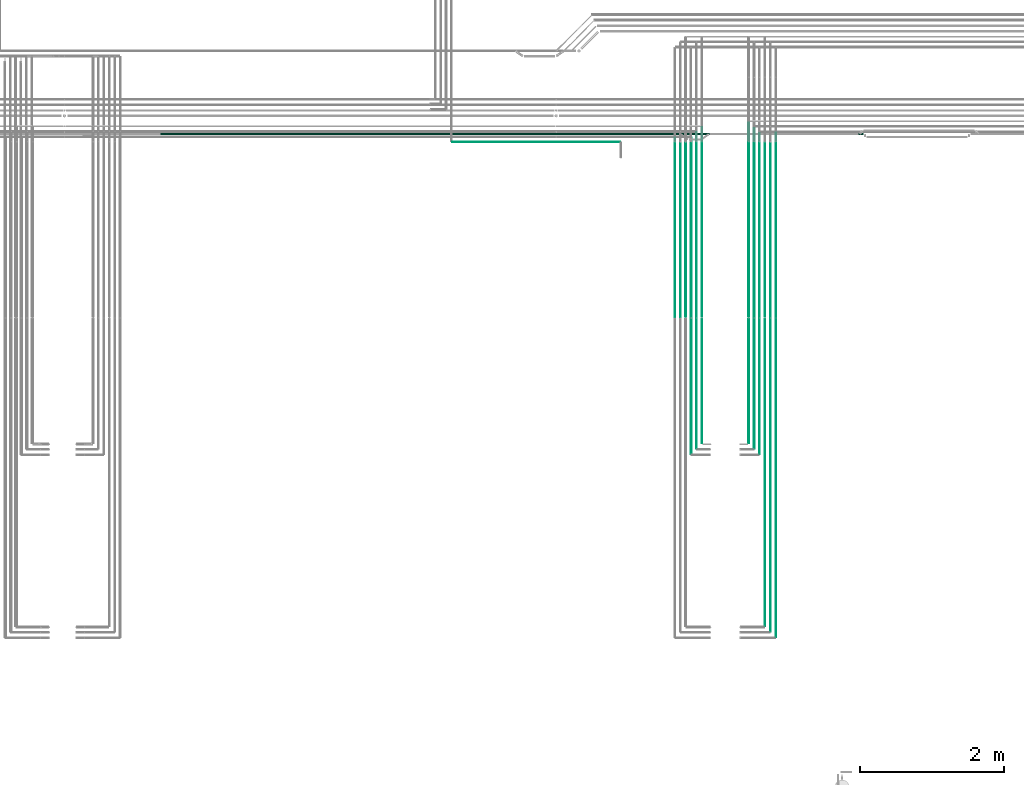
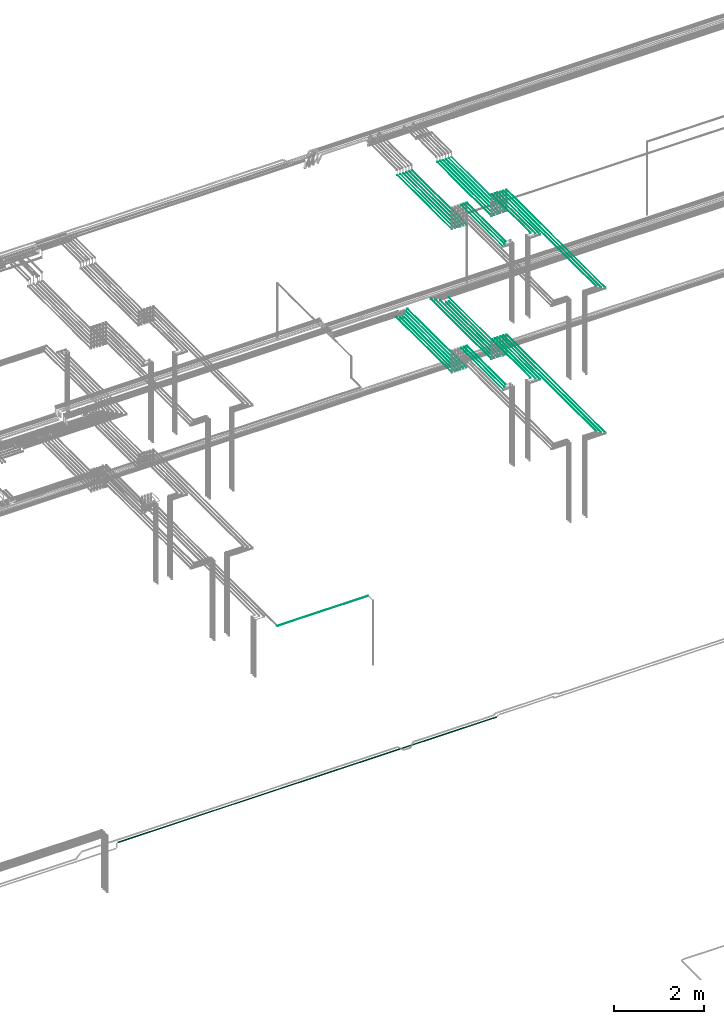
# One storey, part 53 of 331: 44 flow segments.
"""IFC2X3 building model written with IfcOpenShell, lengths in millimetres."""

from ifc_helpers import new_model, entity, si_unit, converted_unit, derived_unit, direction, frame, frame_2d, origin, origin_2d_with_axis, place, context, subcontext, project, spatial, circle, extrude, type_object, element, save


model = new_model("IFC2X3")

# Units and contexts
model_context = context("Model", 3, precision=0.01, world=origin(), true_north=direction((6.12303176911189e-17, 1.0)))
body_context = subcontext(model_context, "Body", "Model", "MODEL_VIEW")
ifc_project = project(units=[si_unit("LENGTHUNIT", "METRE", prefix="MILLI"), si_unit("AREAUNIT", "SQUARE_METRE"), si_unit("VOLUMEUNIT", "CUBIC_METRE"), converted_unit("PLANEANGLEUNIT", "DEGREE", entity("IfcRatioMeasure", 0.0174532925199433), si_unit("PLANEANGLEUNIT", "RADIAN"), dimensions=[0, 0, 0, 0, 0, 0, 0]), si_unit("MASSUNIT", "GRAM", prefix="KILO"), derived_unit("MASSDENSITYUNIT", [(si_unit("MASSUNIT", "GRAM", prefix="KILO"), 1), (si_unit("LENGTHUNIT", "METRE"), -3)]), derived_unit("MOMENTOFINERTIAUNIT", [(si_unit("LENGTHUNIT", "METRE"), 4)]), si_unit("TIMEUNIT", "SECOND"), si_unit("FREQUENCYUNIT", "HERTZ"), si_unit("THERMODYNAMICTEMPERATUREUNIT", "DEGREE_CELSIUS"), derived_unit("THERMALTRANSMITTANCEUNIT", [(si_unit("MASSUNIT", "GRAM", prefix="KILO"), 1), (si_unit("THERMODYNAMICTEMPERATUREUNIT", "KELVIN"), -1), (si_unit("TIMEUNIT", "SECOND"), -3)]), derived_unit("VOLUMETRICFLOWRATEUNIT", [(si_unit("LENGTHUNIT", "METRE"), 3), (si_unit("TIMEUNIT", "SECOND"), -1)]), derived_unit("MASSFLOWRATEUNIT", [(si_unit("MASSUNIT", "GRAM", prefix="KILO"), 1), (si_unit("TIMEUNIT", "SECOND"), -1)]), derived_unit("ROTATIONALFREQUENCYUNIT", [(si_unit("TIMEUNIT", "SECOND"), -1)]), si_unit("ELECTRICCURRENTUNIT", "AMPERE"), si_unit("ELECTRICVOLTAGEUNIT", "VOLT"), si_unit("POWERUNIT", "WATT"), si_unit("FORCEUNIT", "NEWTON", prefix="KILO"), si_unit("ILLUMINANCEUNIT", "LUX"), si_unit("LUMINOUSFLUXUNIT", "LUMEN"), si_unit("LUMINOUSINTENSITYUNIT", "CANDELA"), derived_unit("USERDEFINED", [(si_unit("MASSUNIT", "GRAM", prefix="KILO"), -1), (si_unit("LENGTHUNIT", "METRE"), -2), (si_unit("TIMEUNIT", "SECOND"), 3), (si_unit("LUMINOUSFLUXUNIT", "LUMEN"), 1)]), derived_unit("LINEARVELOCITYUNIT", [(si_unit("LENGTHUNIT", "METRE"), 1), (si_unit("TIMEUNIT", "SECOND"), -1)]), si_unit("PRESSUREUNIT", "PASCAL"), derived_unit("USERDEFINED", [(si_unit("LENGTHUNIT", "METRE"), -2), (si_unit("MASSUNIT", "GRAM", prefix="KILO"), 1), (si_unit("TIMEUNIT", "SECOND"), -2)]), derived_unit("LINEARFORCEUNIT", [(si_unit("MASSUNIT", "GRAM", prefix="KILO"), 1), (si_unit("LENGTHUNIT", "METRE"), 1), (si_unit("TIMEUNIT", "SECOND"), -2), (si_unit("LENGTHUNIT", "METRE"), -1)]), derived_unit("PLANARFORCEUNIT", [(si_unit("MASSUNIT", "GRAM", prefix="KILO"), 1), (si_unit("LENGTHUNIT", "METRE"), 1), (si_unit("TIMEUNIT", "SECOND"), -2), (si_unit("LENGTHUNIT", "METRE"), -2)])], contexts=[model_context])

# Site, building, storey
site_placement = place(None, frame((0.0, -0.00077364408347762, 0.0)))
site = spatial("IfcSite", under=ifc_project, at=site_placement, CompositionType="ELEMENT")
building_placement = place(site_placement, origin())
building = spatial("IfcBuilding", under=site, at=building_placement, CompositionType="ELEMENT")
storey_placement = place(building_placement, origin())
storey = spatial("IfcBuildingStorey", under=building, at=storey_placement, CompositionType="ELEMENT", Elevation=0.0)

# Flow segments
pipe_segment_type = type_object("IfcPipeSegmentType", PredefinedType="NOTDEFINED")
flow_segment_1_placement = place(storey_placement, frame((44639.6371022652, 5653.62056382735, 14544.4047277641)))
element("IfcFlowSegment", 1, at=flow_segment_1_placement, inside=storey, type_object=pipe_segment_type, context=body_context, shape_type="SweptSolid", body=[
    extrude(circle(Radius=4.0, at=frame_2d((1.73258740687743e-11, 0.0), x_axis=(1.0, 0.0))), frame((5.59527223593232, 0.0, 5.59527223591499), z_axis=(0.0, 1.0, 0.0), x_axis=(-1.0, 0.0, 0.0)), (0.0, 0.0, 1.0), 2552.00000000001),
])
flow_segment_2_placement = place(storey_placement, frame((44864.6371022652, 5653.62056382735, 14544.4047277641)))
element("IfcFlowSegment", 2, at=flow_segment_2_placement, inside=storey, type_object=pipe_segment_type, context=body_context, shape_type="SweptSolid", body=[
    extrude(circle(Radius=4.0, at=origin_2d_with_axis()), frame((5.59527223593232, 0.0, 5.59527223591499), z_axis=(0.0, 1.0, 0.0), x_axis=(1.0, 0.0, 0.0)), (0.0, 0.0, 1.0), 2559.0),
])
flow_segment_3_placement = place(storey_placement, frame((44564.6371022651, 5653.62056382735, 14544.4036584537)))
element("IfcFlowSegment", 3, at=flow_segment_3_placement, inside=storey, type_object=pipe_segment_type, context=body_context, shape_type="SweptSolid", body=[
    extrude(circle(Radius=4.0, at=frame_2d((6.064055924071e-11, 0.0), x_axis=(1.0, 0.0))), frame((5.59527223597563, 0.0, 5.59527223591499), z_axis=(0.0, 1.0, 0.0), x_axis=(-1.0, 0.0, 0.0)), (0.0, 0.0, 1.0), 2627.00000000001),
])
flow_segment_4_placement = place(storey_placement, frame((44789.6371022652, 5653.62056382735, 14544.4047277641)))
element("IfcFlowSegment", 4, at=flow_segment_4_placement, inside=storey, type_object=pipe_segment_type, context=body_context, shape_type="SweptSolid", body=[
    extrude(circle(Radius=4.0, at=origin_2d_with_axis()), frame((5.59527223591499, 0.0, 5.59527223591499), z_axis=(0.0, 1.0, 0.0), x_axis=(-1.0, 0.0, 0.0)), (0.0, 0.0, 1.0), 2417.38938002197),
])
flow_segment_5_placement = place(storey_placement, frame((44487.6371022589, 5657.62056382733, 14542.4042817452)))
element("IfcFlowSegment", 5, at=flow_segment_5_placement, inside=storey, type_object=pipe_segment_type, context=body_context, shape_type="SweptSolid", body=[
    extrude(circle(Radius=6.0, at=frame_2d((-5.00717760587577e-09, 0.0), x_axis=(1.0, 0.0))), frame((7.59527224092171, 0.0, 7.5952722359167), z_axis=(0.0, 1.0, 0.0), x_axis=(-1.0, 0.0, 0.0)), (0.0, 0.0, 1.0), 2694.0),
])
flow_segment_6_placement = place(storey_placement, frame((44712.6371022652, 5657.62056382735, 14542.4047277641)))
element("IfcFlowSegment", 6, at=flow_segment_6_placement, inside=storey, type_object=pipe_segment_type, context=body_context, shape_type="SweptSolid", body=[
    extrude(circle(Radius=6.0, at=frame_2d((0.0, -2.16573425859679e-12), x_axis=(1.0, 0.0))), frame((7.59527223591454, 0.0, 7.59527223591887), z_axis=(0.0, 1.0, 0.0), x_axis=(-1.0, 0.0, 0.0)), (0.0, 0.0, 1.0), 2409.00000000001),
])
flow_segment_7_placement = place(storey_placement, frame((44712.6371022652, 1365.48876707932, 15092.4047277641)))
element("IfcFlowSegment", 7, at=flow_segment_7_placement, inside=storey, type_object=pipe_segment_type, context=body_context, shape_type="SweptSolid", body=[
    extrude(circle(Radius=6.0, at=frame_2d((0.0, -2.16573425859679e-12), x_axis=(1.0, 0.0))), frame((7.59527223591454, 0.0, 7.59527223591454), z_axis=(0.0, 1.0, 0.0), x_axis=(1.0, 0.0, 0.0)), (0.0, 0.0, 1.0), 4264.13179674803),
])
flow_segment_8_placement = place(storey_placement, frame((44487.6371022588, 3905.48876707941, 15092.4047277641)))
element("IfcFlowSegment", 8, at=flow_segment_8_placement, inside=storey, type_object=pipe_segment_type, context=body_context, shape_type="SweptSolid", body=[
    extrude(circle(Radius=6.0, at=frame_2d((0.0, -2.16573425859679e-12), x_axis=(1.0, 0.0))), frame((7.59527223591454, 0.0, 7.59527223591454), z_axis=(0.0, 1.0, 0.0), x_axis=(1.0, 0.0, 0.0)), (0.0, 0.0, 1.0), 1724.13179674794),
])
flow_segment_9_placement = place(storey_placement, frame((44789.6371022652, 1286.48876707969, 15094.4047277641)))
element("IfcFlowSegment", 9, at=flow_segment_9_placement, inside=storey, type_object=pipe_segment_type, context=body_context, shape_type="SweptSolid", body=[
    extrude(circle(Radius=4.0, at=origin_2d_with_axis()), frame((5.59527223591499, 0.0, 5.59527223591499), z_axis=(0.0, 1.0, 0.0), x_axis=(1.0, 0.0, 0.0)), (0.0, 0.0, 1.0), 4347.13179674766),
])
flow_segment_10_placement = place(storey_placement, frame((44864.6371022652, 1211.48876707943, 15094.4047277641)))
element("IfcFlowSegment", 10, at=flow_segment_10_placement, inside=storey, type_object=pipe_segment_type, context=body_context, shape_type="SweptSolid", body=[
    extrude(circle(Radius=4.0, at=origin_2d_with_axis()), frame((5.59527223591499, 0.0, 5.59527223591499), z_axis=(0.0, 1.0, 0.0), x_axis=(1.0, 0.0, 0.0)), (0.0, 0.0, 1.0), 4422.13179674791),
])
flow_segment_11_placement = place(storey_placement, frame((44564.6371022652, 3826.48876707969, 15094.4047277641)))
element("IfcFlowSegment", 11, at=flow_segment_11_placement, inside=storey, type_object=pipe_segment_type, context=body_context, shape_type="SweptSolid", body=[
    extrude(circle(Radius=4.0, at=origin_2d_with_axis()), frame((5.59527223591499, 0.0, 5.59527223591499), z_axis=(0.0, 1.0, 0.0), x_axis=(1.0, 0.0, 0.0)), (0.0, 0.0, 1.0), 1807.13179674766),
])
flow_segment_12_placement = place(storey_placement, frame((44639.6371022652, 3751.48876707924, 15094.4047277641)))
element("IfcFlowSegment", 12, at=flow_segment_12_placement, inside=storey, type_object=pipe_segment_type, context=body_context, shape_type="SweptSolid", body=[
    extrude(circle(Radius=4.0, at=origin_2d_with_axis()), frame((5.59527223591499, 0.0, 5.59527223591499), z_axis=(0.0, 1.0, 0.0), x_axis=(1.0, 0.0, 0.0)), (0.0, 0.0, 1.0), 1882.13179674811),
])
flow_segment_13_placement = place(storey_placement, frame((43690.5132590561, 5653.62056382735, 14544.4047277641)))
element("IfcFlowSegment", 13, at=flow_segment_13_placement, inside=storey, type_object=pipe_segment_type, context=body_context, shape_type="SweptSolid", body=[
    extrude(circle(Radius=4.0, at=frame_2d((-1.73258740687743e-11, 0.0), x_axis=(1.0, 0.0))), frame((5.59527223593232, 0.0, 5.59527223591499), z_axis=(0.0, 1.0, 0.0), x_axis=(-1.0, 0.0, 0.0)), (0.0, 0.0, 1.0), 2492.38938002197),
])
flow_segment_14_placement = place(storey_placement, frame((43465.5132590561, 5653.62056382734, 14544.4047277641)))
element("IfcFlowSegment", 14, at=flow_segment_14_placement, inside=storey, type_object=pipe_segment_type, context=body_context, shape_type="SweptSolid", body=[
    extrude(circle(Radius=4.0, at=origin_2d_with_axis()), frame((5.59527223591499, 0.0, 5.59527223591499), z_axis=(0.0, 1.0, 0.0), x_axis=(1.0, 0.0, 0.0)), (0.0, 0.0, 1.0), 2489.38938002196),
])
flow_segment_15_placement = place(storey_placement, frame((43765.5132590561, 5653.62056382735, 14544.4036545967)))
element("IfcFlowSegment", 15, at=flow_segment_15_placement, inside=storey, type_object=pipe_segment_type, context=body_context, shape_type="SweptSolid", body=[
    extrude(circle(Radius=4.0, at=frame_2d((-6.93034962750971e-11, 0.0), x_axis=(1.0, 0.0))), frame((5.59527223598429, 0.0, 5.59527223591499), z_axis=(0.0, 1.0, 0.0), x_axis=(-1.0, 0.0, 0.0)), (0.0, 0.0, 1.0), 2567.38938002197),
])
flow_segment_16_placement = place(storey_placement, frame((43540.5132590561, 5653.62056382735, 14544.4047277641)))
element("IfcFlowSegment", 16, at=flow_segment_16_placement, inside=storey, type_object=pipe_segment_type, context=body_context, shape_type="SweptSolid", body=[
    extrude(circle(Radius=4.0, at=origin_2d_with_axis()), frame((5.59527223591499, 0.0, 5.59527223591499), z_axis=(0.0, 1.0, 0.0), x_axis=(-1.0, 0.0, 0.0)), (0.0, 0.0, 1.0), 2417.38938002197),
])
flow_segment_17_placement = place(storey_placement, frame((43838.5132590526, 5657.62056382733, 14542.4042801686)))
element("IfcFlowSegment", 17, at=flow_segment_17_placement, inside=storey, type_object=pipe_segment_type, context=body_context, shape_type="SweptSolid", body=[
    extrude(circle(Radius=6.0, at=frame_2d((5.0504922910477e-09, -2.16573425859679e-12), x_axis=(1.0, 0.0))), frame((7.59527224096503, 0.0, 7.59527223591887), z_axis=(0.0, 1.0, 0.0), x_axis=(-1.0, 0.0, 0.0)), (0.0, 0.0, 1.0), 2634.38938002197),
])
flow_segment_18_placement = place(storey_placement, frame((43613.5132590561, 5657.62056382735, 14542.4047277641)))
element("IfcFlowSegment", 18, at=flow_segment_18_placement, inside=storey, type_object=pipe_segment_type, context=body_context, shape_type="SweptSolid", body=[
    extrude(circle(Radius=6.0, at=frame_2d((0.0, -2.16573425859679e-12), x_axis=(1.0, 0.0))), frame((7.59527223591454, 0.0, 7.59527223591887), z_axis=(0.0, 1.0, 0.0), x_axis=(-1.0, 0.0, 0.0)), (0.0, 0.0, 1.0), 2409.38938002197),
])
flow_segment_19_placement = place(storey_placement, frame((43838.5132590627, 3905.48876707943, 15142.4047277641)))
element("IfcFlowSegment", 19, at=flow_segment_19_placement, inside=storey, type_object=pipe_segment_type, context=body_context, shape_type="SweptSolid", body=[
    extrude(circle(Radius=6.0, at=frame_2d((0.0, 2.16573425859679e-12), x_axis=(1.0, 0.0))), frame((7.59527223591454, 0.0, 7.59527223591887), z_axis=(0.0, 1.0, 0.0), x_axis=(1.0, 0.0, 0.0)), (0.0, 0.0, 1.0), 1724.13179674792),
])
flow_segment_20_placement = place(storey_placement, frame((43765.5132590561, 3826.48876707969, 15144.4047277641)))
element("IfcFlowSegment", 20, at=flow_segment_20_placement, inside=storey, type_object=pipe_segment_type, context=body_context, shape_type="SweptSolid", body=[
    extrude(circle(Radius=4.0, at=origin_2d_with_axis()), frame((5.59527223591499, 0.0, 5.59527223591499), z_axis=(0.0, 1.0, 0.0), x_axis=(1.0, 0.0, 0.0)), (0.0, 0.0, 1.0), 1807.13179674766),
])
flow_segment_21_placement = place(storey_placement, frame((43690.5132590561, 3751.48876707928, 15144.4047277641)))
element("IfcFlowSegment", 21, at=flow_segment_21_placement, inside=storey, type_object=pipe_segment_type, context=body_context, shape_type="SweptSolid", body=[
    extrude(circle(Radius=4.0, at=origin_2d_with_axis()), frame((5.59527223591499, 0.0, 5.59527223591499), z_axis=(0.0, 1.0, 0.0), x_axis=(1.0, 0.0, 0.0)), (0.0, 0.0, 1.0), 1882.13179674807),
])
flow_segment_22_placement = place(building_placement, frame((40380.8306299097, 8077.89832457637, 7244.40472776409)))
element("IfcFlowSegment", 22, at=flow_segment_22_placement, inside=storey, type_object=pipe_segment_type, context=body_context, shape_type="SweptSolid", body=[
    extrude(circle(Radius=4.0, at=origin_2d_with_axis()), frame((0.0, 5.59527223591607, 5.59527223591607), z_axis=(1.0, 0.0, 0.0), x_axis=(0.0, -1.0, 0.0)), (0.0, 0.0, 1.0), 2330.87880607742),
])
flow_segment_23_placement = place(storey_placement, frame((43689.4468045266, 5653.62056382734, 18444.404727764)))
element("IfcFlowSegment", 23, at=flow_segment_23_placement, inside=storey, type_object=pipe_segment_type, context=body_context, shape_type="SweptSolid", body=[
    extrude(circle(Radius=4.0, at=origin_2d_with_axis()), frame((5.59527223591499, 0.0, 5.59527223591499), z_axis=(0.0, 1.0, 0.0), x_axis=(1.0, 0.0, 0.0)), (0.0, 0.0, 1.0), 2426.52824282761),
])
flow_segment_24_placement = place(storey_placement, frame((43464.4468045266, 5653.62056382734, 18444.4047277641)))
element("IfcFlowSegment", 24, at=flow_segment_24_placement, inside=storey, type_object=pipe_segment_type, context=body_context, shape_type="SweptSolid", body=[
    extrude(circle(Radius=4.0, at=frame_2d((8.66293703438714e-12, 0.0), x_axis=(1.0, 0.0))), frame((5.59527223591499, 0.0, 5.59527223591499), z_axis=(0.0, 1.0, 0.0), x_axis=(-1.0, 0.0, 0.0)), (0.0, 0.0, 1.0), 2426.52824282753),
])
flow_segment_25_placement = place(storey_placement, frame((43764.4468045266, 5653.62056382735, 18444.4047277641)))
element("IfcFlowSegment", 25, at=flow_segment_25_placement, inside=storey, type_object=pipe_segment_type, context=body_context, shape_type="SweptSolid", body=[
    extrude(circle(Radius=4.0, at=origin_2d_with_axis()), frame((5.59527223591499, 0.0, 5.59527223591499), z_axis=(0.0, 1.0, 0.0), x_axis=(1.0, 0.0, 0.0)), (0.0, 0.0, 1.0), 2426.5282428276),
])
flow_segment_26_placement = place(storey_placement, frame((43539.4468045266, 5653.62056382734, 18444.4047277641)))
element("IfcFlowSegment", 26, at=flow_segment_26_placement, inside=storey, type_object=pipe_segment_type, context=body_context, shape_type="SweptSolid", body=[
    extrude(circle(Radius=4.0, at=origin_2d_with_axis()), frame((5.59527223591499, 0.0, 5.59527223591499), z_axis=(0.0, 1.0, 0.0), x_axis=(-1.0, 0.0, 0.0)), (0.0, 0.0, 1.0), 2426.52824282759),
])
flow_segment_27_placement = place(storey_placement, frame((43837.4468045266, 5657.62056382736, 18442.4047277641)))
element("IfcFlowSegment", 27, at=flow_segment_27_placement, inside=storey, type_object=pipe_segment_type, context=body_context, shape_type="SweptSolid", body=[
    extrude(circle(Radius=6.0, at=origin_2d_with_axis()), frame((7.59527223591454, 0.0, 7.5952722359167), z_axis=(0.0, 1.0, 0.0), x_axis=(1.0, 0.0, 0.0)), (0.0, 0.0, 1.0), 2418.52824282759),
])
flow_segment_28_placement = place(storey_placement, frame((43612.4468045266, 5657.62056382735, 18442.4047277641)))
element("IfcFlowSegment", 28, at=flow_segment_28_placement, inside=storey, type_object=pipe_segment_type, context=body_context, shape_type="SweptSolid", body=[
    extrude(circle(Radius=6.0, at=origin_2d_with_axis()), frame((7.59527223591454, 0.0, 7.5952722359167), z_axis=(0.0, 1.0, 0.0), x_axis=(1.0, 0.0, 0.0)), (0.0, 0.0, 1.0), 2418.52824282761),
])
flow_segment_29_placement = place(storey_placement, frame((43837.4468045266, 3905.4887670797, 19042.4047277641)))
element("IfcFlowSegment", 29, at=flow_segment_29_placement, inside=storey, type_object=pipe_segment_type, context=body_context, shape_type="SweptSolid", body=[
    extrude(circle(Radius=6.0, at=origin_2d_with_axis()), frame((7.59527223591454, 0.0, 7.5952722359167), z_axis=(0.0, 1.0, 0.0), x_axis=(1.0, 0.0, 0.0)), (0.0, 0.0, 1.0), 1724.13179674766),
])
flow_segment_30_placement = place(storey_placement, frame((43764.4468045266, 3826.48876707969, 19044.4047277641)))
element("IfcFlowSegment", 30, at=flow_segment_30_placement, inside=storey, type_object=pipe_segment_type, context=body_context, shape_type="SweptSolid", body=[
    extrude(circle(Radius=4.0, at=origin_2d_with_axis()), frame((5.59527223591499, 0.0, 5.59527223591499), z_axis=(0.0, 1.0, 0.0), x_axis=(1.0, 0.0, 0.0)), (0.0, 0.0, 1.0), 1807.13179674766),
])
flow_segment_31_placement = place(storey_placement, frame((43689.4468045266, 3751.48876707969, 19044.4047277641)))
element("IfcFlowSegment", 31, at=flow_segment_31_placement, inside=storey, type_object=pipe_segment_type, context=body_context, shape_type="SweptSolid", body=[
    extrude(circle(Radius=4.0, at=origin_2d_with_axis()), frame((5.59527223591499, 0.0, 5.59527223591499), z_axis=(0.0, 1.0, 0.0), x_axis=(1.0, 0.0, 0.0)), (0.0, 0.0, 1.0), 1882.13179674766),
])
flow_segment_32_placement = place(storey_placement, frame((44639.5706481368, 5653.62056382734, 18444.404727764)))
element("IfcFlowSegment", 32, at=flow_segment_32_placement, inside=storey, type_object=pipe_segment_type, context=body_context, shape_type="SweptSolid", body=[
    extrude(circle(Radius=4.0, at=origin_2d_with_axis()), frame((5.59527223592365, 0.0, 5.59527223591499), z_axis=(0.0, 1.0, 0.0), x_axis=(1.0, 0.0, 0.0)), (0.0, 0.0, 1.0), 2426.52824282761),
])
flow_segment_33_placement = place(storey_placement, frame((44864.5706481368, 5653.62056382734, 18444.4047277641)))
element("IfcFlowSegment", 33, at=flow_segment_33_placement, inside=storey, type_object=pipe_segment_type, context=body_context, shape_type="SweptSolid", body=[
    extrude(circle(Radius=4.0, at=origin_2d_with_axis()), frame((5.59527223591499, 0.0, 5.59527223591499), z_axis=(0.0, 1.0, 0.0), x_axis=(-1.0, 0.0, 0.0)), (0.0, 0.0, 1.0), 2426.52824282753),
])
flow_segment_34_placement = place(storey_placement, frame((44564.5706481368, 5653.62056382735, 18444.4047277641)))
element("IfcFlowSegment", 34, at=flow_segment_34_placement, inside=storey, type_object=pipe_segment_type, context=body_context, shape_type="SweptSolid", body=[
    extrude(circle(Radius=4.0, at=origin_2d_with_axis()), frame((5.59527223591499, 0.0, 5.59527223591499), z_axis=(0.0, 1.0, 0.0), x_axis=(1.0, 0.0, 0.0)), (0.0, 0.0, 1.0), 2426.5282428276),
])
flow_segment_35_placement = place(storey_placement, frame((44789.5706481368, 5653.62056382734, 18444.4047277641)))
element("IfcFlowSegment", 35, at=flow_segment_35_placement, inside=storey, type_object=pipe_segment_type, context=body_context, shape_type="SweptSolid", body=[
    extrude(circle(Radius=4.0, at=origin_2d_with_axis()), frame((5.59527223591499, 0.0, 5.59527223591499), z_axis=(0.0, 1.0, 0.0), x_axis=(-1.0, 0.0, 0.0)), (0.0, 0.0, 1.0), 2426.52824282759),
])
flow_segment_36_placement = place(storey_placement, frame((44487.5706481368, 5657.62056382736, 18442.4047277641)))
element("IfcFlowSegment", 36, at=flow_segment_36_placement, inside=storey, type_object=pipe_segment_type, context=body_context, shape_type="SweptSolid", body=[
    extrude(circle(Radius=6.0, at=origin_2d_with_axis()), frame((7.59527223591454, 0.0, 7.5952722359167), z_axis=(0.0, 1.0, 0.0), x_axis=(1.0, 0.0, 0.0)), (0.0, 0.0, 1.0), 2418.52824282759),
])
flow_segment_37_placement = place(storey_placement, frame((44712.5706481368, 5657.62056382735, 18442.4047277641)))
element("IfcFlowSegment", 37, at=flow_segment_37_placement, inside=storey, type_object=pipe_segment_type, context=body_context, shape_type="SweptSolid", body=[
    extrude(circle(Radius=6.0, at=origin_2d_with_axis()), frame((7.59527223591454, 0.0, 7.5952722359167), z_axis=(0.0, 1.0, 0.0), x_axis=(1.0, 0.0, 0.0)), (0.0, 0.0, 1.0), 2418.52824282761),
])
flow_segment_38_placement = place(storey_placement, frame((44712.5706481368, 1365.48876707969, 19042.4047277641)))
element("IfcFlowSegment", 38, at=flow_segment_38_placement, inside=storey, type_object=pipe_segment_type, context=body_context, shape_type="SweptSolid", body=[
    extrude(circle(Radius=6.0, at=origin_2d_with_axis()), frame((7.59527223591454, 0.0, 7.5952722359167), z_axis=(0.0, 1.0, 0.0), x_axis=(1.0, 0.0, 0.0)), (0.0, 0.0, 1.0), 4264.13179674766),
])
flow_segment_39_placement = place(storey_placement, frame((44487.5706481368, 3905.4887670797, 19042.4047277641)))
element("IfcFlowSegment", 39, at=flow_segment_39_placement, inside=storey, type_object=pipe_segment_type, context=body_context, shape_type="SweptSolid", body=[
    extrude(circle(Radius=6.0, at=origin_2d_with_axis()), frame((7.59527223591454, 0.0, 7.5952722359167), z_axis=(0.0, 1.0, 0.0), x_axis=(1.0, 0.0, 0.0)), (0.0, 0.0, 1.0), 1724.13179674766),
])
flow_segment_40_placement = place(storey_placement, frame((44789.5706481368, 1286.48876707969, 19044.4047277641)))
element("IfcFlowSegment", 40, at=flow_segment_40_placement, inside=storey, type_object=pipe_segment_type, context=body_context, shape_type="SweptSolid", body=[
    extrude(circle(Radius=4.0, at=origin_2d_with_axis()), frame((5.59527223591499, 0.0, 5.59527223591499), z_axis=(0.0, 1.0, 0.0), x_axis=(1.0, 0.0, 0.0)), (0.0, 0.0, 1.0), 4347.13179674766),
])
flow_segment_41_placement = place(storey_placement, frame((44864.5706481368, 1211.48876707969, 19044.4047277641)))
element("IfcFlowSegment", 41, at=flow_segment_41_placement, inside=storey, type_object=pipe_segment_type, context=body_context, shape_type="SweptSolid", body=[
    extrude(circle(Radius=4.0, at=origin_2d_with_axis()), frame((5.59527223591499, 0.0, 5.59527223591499), z_axis=(0.0, 1.0, 0.0), x_axis=(1.0, 0.0, 0.0)), (0.0, 0.0, 1.0), 4422.13179674766),
])
flow_segment_42_placement = place(storey_placement, frame((44564.5706481368, 3826.48876707969, 19044.4047277641)))
element("IfcFlowSegment", 42, at=flow_segment_42_placement, inside=storey, type_object=pipe_segment_type, context=body_context, shape_type="SweptSolid", body=[
    extrude(circle(Radius=4.0, at=origin_2d_with_axis()), frame((5.59527223591499, 0.0, 5.59527223591499), z_axis=(0.0, 1.0, 0.0), x_axis=(1.0, 0.0, 0.0)), (0.0, 0.0, 1.0), 1807.13179674766),
])
flow_segment_43_placement = place(storey_placement, frame((44639.5706481368, 3751.48876707969, 19044.4047277641)))
element("IfcFlowSegment", 43, at=flow_segment_43_placement, inside=storey, type_object=pipe_segment_type, context=body_context, shape_type="SweptSolid", body=[
    extrude(circle(Radius=4.0, at=origin_2d_with_axis()), frame((5.59527223591499, 0.0, 5.59527223591499), z_axis=(0.0, 1.0, 0.0), x_axis=(1.0, 0.0, 0.0)), (0.0, 0.0, 1.0), 1882.13179674766),
])
flow_segment_44_placement = place(building_placement, frame((36330.3635215668, 8182.92098945676, 2687.40472776403)))
element("IfcFlowSegment", 44, at=flow_segment_44_placement, inside=storey, type_object=pipe_segment_type, context=body_context, shape_type="SweptSolid", body=[
    extrude(circle(Radius=11.0, at=origin_2d_with_axis()), frame((0.0, 12.5952722359156, 12.5952722359161), z_axis=(1.0, 0.0, 0.0), x_axis=(0.0, 1.0, 0.0)), (0.0, 0.0, 1.0), 9755.43480838352),
])

save(model, "model.ifc")
